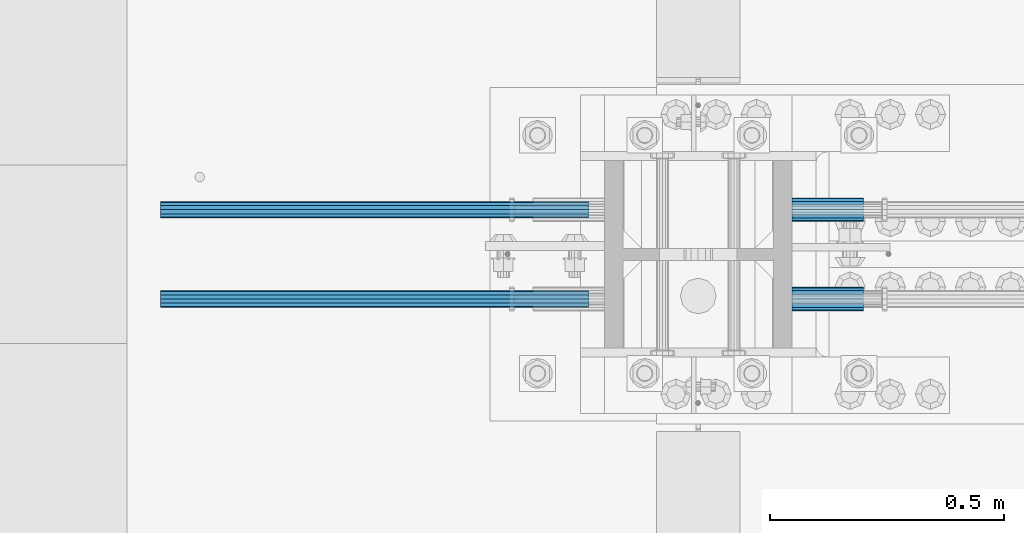
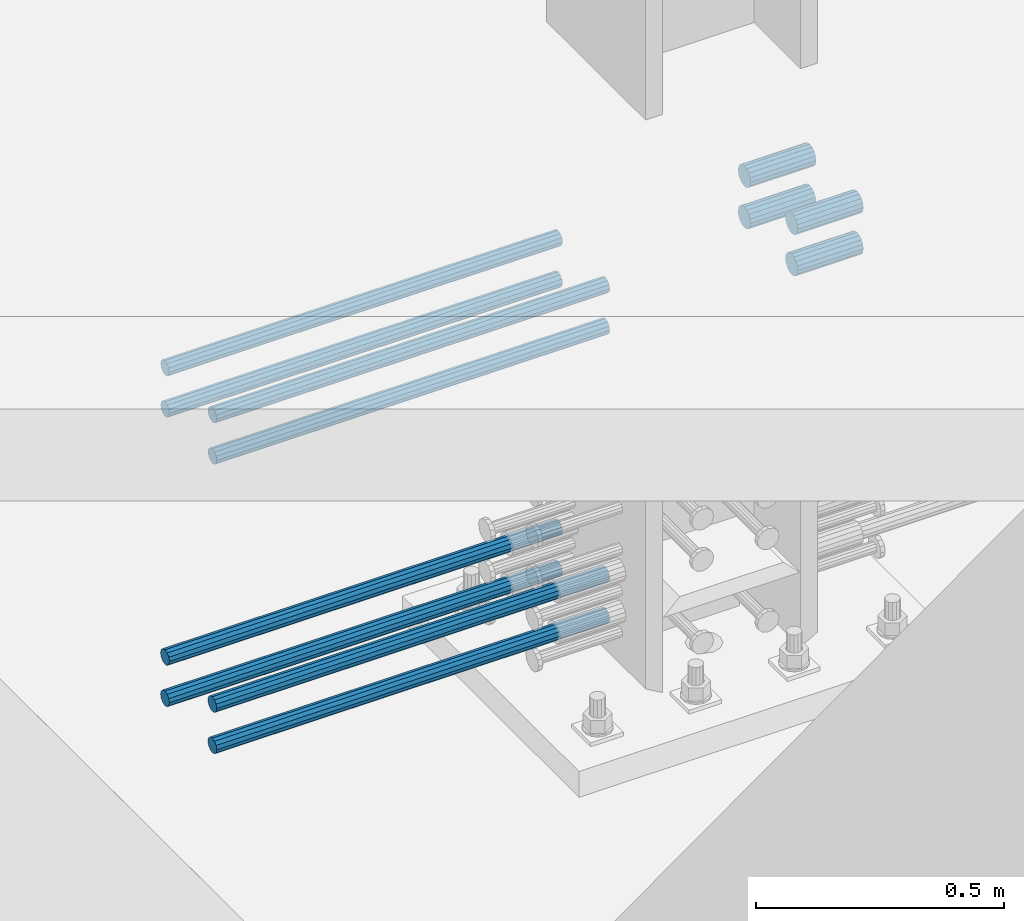
# One storey, part 1188 of 1763: 12 beams, 9 elements without a shape of their own.
"""IFC2X3 building model written with IfcOpenShell, lengths in millimetres."""

import ifcopenshell
import ifcopenshell.guid

model = None  # the IFC model being written
_history = None  # IfcOwnerHistory: only IFC2X3 demands one
_inside = {}  # id of a spatial element -> (the spatial element, [elements in it])
_under = {}  # id of a project, library or spatial element -> (it, [spatial elements below it])
_declared = {}  # id of a project -> (the project, [libraries it declares])
_typed = {}  # id of a type object -> (the type object, [elements of that type])
_made_of = {}  # id of a material, layer set ... -> (it, [elements and type objects made of it])


def new_model(schema):
    """Start an empty IFC model of exactly this schema.

    Asked for "IFC4X3", IfcOpenShell would pick the latest addendum, in which some entities
    have other attributes; the version numbers below select the first issue.
    IFC2X3 requires an IfcOwnerHistory on every rooted entity: one is made here for all.
    """
    global model, _history
    if schema == "IFC4X3":
        model = ifcopenshell.file(schema_version=(4, 3, 0, 0))
    else:
        model = ifcopenshell.file(schema=schema)
    _inside.clear()
    _under.clear()
    _declared.clear()
    _typed.clear()
    _made_of.clear()
    _history = None
    if model.schema == "IFC2X3":
        org = make("IfcOrganization", Name="unknown")
        user = make(
            "IfcPersonAndOrganization",
            ThePerson=make("IfcPerson", FamilyName="unknown"),
            TheOrganization=org,
        )
        app = make(
            "IfcApplication",
            ApplicationDeveloper=org,
            Version="unknown",
            ApplicationFullName="unknown",
            ApplicationIdentifier="unknown",
        )
        _history = make(
            "IfcOwnerHistory",
            OwningUser=user,
            OwningApplication=app,
            ChangeAction="ADDED",
            CreationDate=0,
        )
    return model


def make(cls, **values):
    """One entity of the class cls with the attributes given. An attribute that is None is left unset."""
    return model.create_entity(
        cls, **{name: value for name, value in values.items() if value is not None}
    )


def rooted(cls, **values):
    """An entity with a GlobalId (a new one), such as an element, a storey or a relation."""
    return make(cls, GlobalId=ifcopenshell.guid.new(), OwnerHistory=_history, **values)


def si_unit(unit_type, name, prefix=None):
    """IfcSIUnit, for example si_unit("LENGTHUNIT", "METRE", prefix="MILLI")."""
    return make("IfcSIUnit", UnitType=unit_type, Prefix=prefix, Name=name)


def assignment(units):
    """IfcUnitAssignment: the units of a project."""
    return None if units is None else make("IfcUnitAssignment", Units=units)


def point(xyz):
    """IfcCartesianPoint."""
    return None if xyz is None else make("IfcCartesianPoint", Coordinates=xyz)


def direction(xyz):
    """IfcDirection."""
    return None if xyz is None else make("IfcDirection", DirectionRatios=xyz)


def frame(location, z_axis=None, x_axis=None):
    """IfcAxis2Placement3D, a coordinate frame: its origin and axes. An axis left out is left unset."""
    return make(
        "IfcAxis2Placement3D",
        Location=point(location),
        Axis=direction(z_axis),
        RefDirection=direction(x_axis),
    )


def origin_with_axes():
    """The frame at (0, 0, 0) with the z axis (0, 0, 1) and the x axis (1, 0, 0) written out."""
    return frame((0.0, 0.0, 0.0), z_axis=(0.0, 0.0, 1.0), x_axis=(1.0, 0.0, 0.0))


def place(relative_to, where):
    """IfcLocalPlacement: puts the frame where relative to a parent placement (None: the world)."""
    return make(
        "IfcLocalPlacement", PlacementRelTo=relative_to, RelativePlacement=where
    )


def context(
    kind, dimensions, precision=None, world=None, true_north=None, identifier=None
):
    """IfcGeometricRepresentationContext, for example the 3D "Model" context."""
    return make(
        "IfcGeometricRepresentationContext",
        ContextIdentifier=identifier,
        ContextType=kind,
        CoordinateSpaceDimension=dimensions,
        Precision=precision,
        WorldCoordinateSystem=world,
        TrueNorth=true_north,
    )


def subcontext(parent, identifier, kind, view, scale=None):
    """IfcGeometricRepresentationSubContext, for example "Body" below "Model"."""
    return make(
        "IfcGeometricRepresentationSubContext",
        ContextIdentifier=identifier,
        ContextType=kind,
        ParentContext=parent,
        TargetScale=scale,
        TargetView=view,
    )


def project(units=None, contexts=None):
    """IfcProject with its units and contexts."""
    return rooted(
        "IfcProject",
        Name="project",
        RepresentationContexts=contexts,
        UnitsInContext=assignment(units),
    )


def spatial(cls, under=None, at=None, **own):
    """A site, building, storey or space (cls), placed at a placement, below another one or the project."""
    s = rooted(cls, ObjectPlacement=at, **own)
    if under is not None:
        _under.setdefault(under.id(), (under, []))[1].append(s)
    return s


def faces_of(points, faces, orient=None, outer=None):
    """IfcFace entities. A face is a list of loops; a loop is a list of indices into points, from 0.

    orient and outer hold one flag for each loop. By default every Orientation is true, the
    first loop of a face is its IfcFaceOuterBound and the others are IfcFaceBound.
    """
    made = []
    for i, loops in enumerate(faces):
        bounds = []
        for j, loop in enumerate(loops):
            is_outer = j == 0 if outer is None else outer[i][j]
            bounds.append(
                make(
                    "IfcFaceOuterBound" if is_outer else "IfcFaceBound",
                    Bound=make("IfcPolyLoop", Polygon=[points[k] for k in loop]),
                    Orientation=True if orient is None else orient[i][j],
                )
            )
        made.append(make("IfcFace", Bounds=bounds))
    return made


def faceted_brep(points, faces, orient=None, outer=None, voids=None):
    """IfcFacetedBrep: a solid bounded by flat faces; with voids (closed shells), ...WithVoids."""
    shared = [point(p) for p in points]
    hull = make("IfcClosedShell", CfsFaces=faces_of(shared, faces, orient, outer))
    if voids is None:
        return make("IfcFacetedBrep", Outer=hull)
    return make(
        "IfcFacetedBrepWithVoids",
        Outer=hull,
        Voids=[
            make(cls, CfsFaces=faces_of(shared, fs, o, b)) for cls, fs, o, b in voids
        ],
    )


def shape(context_of_items, identifier, shape_type, items):
    """IfcShapeRepresentation: the items that make up one representation, for example the "Body"."""
    return make(
        "IfcShapeRepresentation",
        ContextOfItems=context_of_items,
        RepresentationIdentifier=identifier,
        RepresentationType=shape_type,
        Items=items,
    )


def material(Name=None, Category=None):
    """IfcMaterial."""
    return make("IfcMaterial", Name=Name, Category=Category)


def made_of(thing, what):
    """Note that an element or type object is made of a material, layer set ...; save() writes the relation."""
    if what is not None:
        _made_of.setdefault(what.id(), (what, []))[1].append(thing)
    return thing


def type_object(cls, material=None, **own):
    """A type object (cls), such as IfcWallType, which elements share."""
    return made_of(rooted(cls, **own), material)


def element(
    cls,
    number,
    at=None,
    inside=None,
    cuts=None,
    type_object=None,
    material=None,
    context=None,
    identifier="Body",
    shape_type=None,
    held_by="IfcProductDefinitionShape",
    body=None,
    shapes=None,
    **own,
):
    """One element of the class cls, such as IfcWall. Its Tag is "e" and its number.

    at: its placement. inside: the storey or other place that contains it. cuts: it is an
    opening in that element (IfcRelVoidsElement). A single representation is given by context,
    identifier, shape_type and body (its items); several are given by shapes. held_by: the class
    of the entity that holds the representations. save() writes the other relations.
    """
    e = rooted(cls, Tag="e%d" % number, ObjectPlacement=at, **own)
    if body is not None:
        shapes = [shape(context, identifier, shape_type, body)]
    if shapes is not None:
        e.Representation = make(held_by, Representations=shapes)
    if inside is not None:
        _inside.setdefault(inside.id(), (inside, []))[1].append(e)
    if cuts is not None:
        rooted(
            "IfcRelVoidsElement", RelatingBuildingElement=cuts, RelatedOpeningElement=e
        )
    if type_object is not None:
        _typed.setdefault(type_object.id(), (type_object, []))[1].append(e)
    return made_of(e, material)


def aggregate(whole, parts):
    """IfcRelAggregates: a whole, such as a stair, and the parts it consists of."""
    return rooted("IfcRelAggregates", RelatingObject=whole, RelatedObjects=parts)


def save(model, path):
    """Write the relations noted so far, then the file.

    IfcRelAggregates (storeys below a building ...), IfcRelContainedInSpatialStructure (elements
    in a storey), IfcRelDefinesByType, IfcRelAssociatesMaterial and IfcRelDeclares: one each for
    every whole, place, type object, material and project.
    """
    for whole, parts in _under.values():
        aggregate(whole, parts)
    for where, things in _inside.values():
        rooted(
            "IfcRelContainedInSpatialStructure",
            RelatedElements=things,
            RelatingStructure=where,
        )
    for kind, things in _typed.values():
        rooted("IfcRelDefinesByType", RelatedObjects=things, RelatingType=kind)
    for what, things in _made_of.values():
        rooted("IfcRelAssociatesMaterial", RelatedObjects=things, RelatingMaterial=what)
    for by, libraries in _declared.values():
        rooted("IfcRelDeclares", RelatingContext=by, RelatedDefinitions=libraries)
    model.write(path)


model = new_model("IFC2X3")

# Units and contexts
model_context = context("Model", 3, precision=1e-05, world=origin_with_axes())
body_context = subcontext(model_context, "Body", "Model", "MODEL_VIEW")
ifc_project = project(units=[si_unit("LENGTHUNIT", "METRE", prefix="MILLI"), si_unit("AREAUNIT", "SQUARE_METRE"), si_unit("VOLUMEUNIT", "CUBIC_METRE"), si_unit("MASSUNIT", "GRAM", prefix="KILO"), si_unit("TIMEUNIT", "SECOND"), si_unit("PLANEANGLEUNIT", "RADIAN"), si_unit("SOLIDANGLEUNIT", "STERADIAN"), si_unit("THERMODYNAMICTEMPERATUREUNIT", "DEGREE_CELSIUS"), si_unit("LUMINOUSINTENSITYUNIT", "LUMEN")], contexts=[model_context])

# Site, building, storey
site_placement = place(None, origin_with_axes())
site = spatial("IfcSite", under=ifc_project, at=site_placement, CompositionType="ELEMENT")
building_placement = place(site_placement, origin_with_axes())
building = spatial("IfcBuilding", under=site, at=building_placement, Name="Undefined", CompositionType="ELEMENT")
storey_placement = place(building_placement, origin_with_axes())
storey = spatial("IfcBuildingStorey", under=building, at=storey_placement, Name="Undefined", CompositionType="ELEMENT", Elevation=0.0)

# Assembly, beams
assembly_1_placement = place(storey_placement, origin_with_axes())
assembly_1 = element("IfcElementAssembly", 1, at=assembly_1_placement, inside=storey, Name="COLUMN", AssemblyPlace="NOTDEFINED", PredefinedType="RIGID_FRAME")
ifc_material = material(Name="STEEL/A706-GR.80")
beam_type_1 = type_object("IfcBeamType", PredefinedType="NOTDEFINED")
beam_1_placement = place(assembly_1_placement, frame((-72291.0122736972, 552.450000000255, 4775.20000000008), z_axis=(0.0, 0.0, 1.0), x_axis=(1.0, 0.0, 0.0)))
beam_1 = element("IfcBeam", 2, at=beam_1_placement, type_object=beam_type_1, material=ifc_material, Name="HALF COUPLER F", context=body_context, shape_type="Brep", body=[
    faceted_brep([(32.7659999999996, -8.95349999999962, -15.507916905568), (32.7659999999996, 0.0, -17.9070000000002), (32.7659999999996, 8.95349999999962, -15.507916905568), (32.7659999999996, 15.507916905568, -8.95350000000008), (32.7659999999996, 17.9069999999992, 0.0), (32.7659999999996, 15.507916905568, 8.95350000000008), (32.7659999999996, 8.95349999999962, 15.507916905568), (32.7659999999996, 0.0, 17.9070000000002), (32.7659999999996, -8.95349999999962, 15.507916905568), (32.7659999999996, -15.507916905568, 8.95350000000008), (32.7659999999996, -17.9069999999992, 0.0), (32.7659999999996, -15.507916905568, -8.95350000000008), (152.400103102711, -15.507916905568, 8.95350000000008), (152.400103102711, -8.95349999999962, 15.507916905568), (152.400103102711, -17.9069999999992, 0.0), (152.400103102711, -15.507916905568, -8.95350000000008), (152.400103102711, -8.95349999999962, -15.507916905568), (152.400103102711, 0.0, -17.9070000000002), (152.400103102711, 8.95349999999962, -15.507916905568), (152.400103102711, 15.507916905568, -8.95350000000008), (152.400103102711, 17.9069999999992, 0.0), (152.400103102711, 15.507916905568, 8.95350000000008), (152.400103102711, 8.95349999999962, 15.507916905568), (152.400103102711, 0.0, 17.9070000000002), (0.0, -23.466540125788, 9.72015918207308), (0.0, -17.9605122421381, 17.9605122421385), (0.0, -9.72015918207398, 23.4665401257867), (0.0, 0.0, 25.4000000000001), (0.0, 9.72015918207398, 23.4665401257867), (0.0, 17.9605122421381, 17.9605122421385), (0.0, 23.466540125788, 9.72015918207308), (0.0, 25.4000000000015, 0.0), (0.0, 23.466540125788, -9.72015918207308), (0.0, 17.9605122421381, -17.9605122421385), (0.0, 9.72015918207398, -23.4665401257867), (0.0, 0.0, -25.4000000000001), (0.0, -9.72015918207398, -23.4665401257867), (0.0, -17.9605122421381, -17.9605122421385), (0.0, -23.466540125788, -9.72015918207308), (0.0, -25.4000000000015, 0.0), (152.400103102711, -25.4000000000015, 0.0), (152.400103102711, -23.466540125788, 9.72015918207308), (152.400103102711, -17.9605122421381, 17.9605122421385), (152.400103102711, -9.72015918207398, 23.4665401257867), (152.400103102711, 0.0, 25.4000000000001), (152.400103102711, 9.72015918207398, 23.4665401257867), (152.400103102711, 17.9605122421381, 17.9605122421385), (152.400103102711, 23.466540125788, 9.72015918207308), (152.400103102711, 25.4000000000015, 0.0), (152.400103102711, 23.466540125788, -9.72015918207308), (152.400103102711, 17.9605122421381, -17.9605122421385), (152.400103102711, 9.72015918207398, -23.4665401257867), (152.400103102711, 0.0, -25.4000000000001), (152.400103102711, -9.72015918207398, -23.4665401257867), (152.400103102711, -17.9605122421381, -17.9605122421385), (152.400103102711, -23.466540125788, -9.72015918207308)], [[[0, 1, 2, 3, 4, 5, 6, 7, 8, 9, 10, 11]], [[12, 9, 8, 13]], [[14, 10, 9, 12]], [[15, 11, 10, 14]], [[16, 0, 11, 15]], [[17, 1, 0, 16]], [[18, 2, 1, 17]], [[19, 3, 2, 18]], [[20, 4, 3, 19]], [[21, 5, 4, 20]], [[22, 6, 5, 21]], [[23, 7, 6, 22]], [[13, 8, 7, 23]], [[24, 25, 26, 27, 28, 29, 30, 31, 32, 33, 34, 35, 36, 37, 38, 39]], [[24, 39, 40, 41]], [[25, 24, 41, 42]], [[26, 25, 42, 43]], [[27, 26, 43, 44]], [[28, 27, 44, 45]], [[29, 28, 45, 46]], [[30, 29, 46, 47]], [[31, 30, 47, 48]], [[32, 31, 48, 49]], [[33, 32, 49, 50]], [[34, 33, 50, 51]], [[35, 34, 51, 52]], [[36, 35, 52, 53]], [[37, 36, 53, 54]], [[38, 37, 54, 55]], [[39, 38, 55, 40]], [[54, 53, 52, 51, 50, 49, 48, 47, 46, 45, 44, 43, 42, 41, 40, 55], [21, 20, 19, 18, 17, 16, 15, 14, 12, 13, 23, 22]]]),
])
beam_2_placement = place(assembly_1_placement, frame((-72291.012342359, 361.950000000843, 4775.20000000008), z_axis=(0.0, 0.0, 1.0), x_axis=(1.0, 0.0, 0.0)))
beam_2 = element("IfcBeam", 3, at=beam_2_placement, type_object=beam_type_1, material=ifc_material, Name="HALF COUPLER F", context=body_context, shape_type="Brep", body=[
    faceted_brep([(32.7659999999996, -8.95349999999962, -15.507916905568), (32.7659999999996, 0.0, -17.9070000000002), (32.7659999999996, 8.95349999999962, -15.507916905568), (32.7659999999996, 15.507916905568, -8.95350000000008), (32.7659999999996, 17.9069999999992, 0.0), (32.7659999999996, 15.507916905568, 8.95350000000008), (32.7659999999996, 8.95349999999962, 15.507916905568), (32.7659999999996, 0.0, 17.9070000000002), (32.7659999999996, -8.95349999999962, 15.507916905568), (32.7659999999996, -15.507916905568, 8.95350000000008), (32.7659999999996, -17.9069999999992, 0.0), (32.7659999999996, -15.507916905568, -8.95350000000008), (152.400103102711, -15.507916905568, 8.95350000000008), (152.400103102711, -8.95349999999962, 15.507916905568), (152.400103102711, -17.9069999999992, 0.0), (152.400103102711, -15.507916905568, -8.95350000000008), (152.400103102711, -8.95349999999962, -15.507916905568), (152.400103102711, 0.0, -17.9070000000002), (152.400103102711, 8.95349999999962, -15.507916905568), (152.400103102711, 15.507916905568, -8.95350000000008), (152.400103102711, 17.9069999999992, 0.0), (152.400103102711, 15.507916905568, 8.95350000000008), (152.400103102711, 8.95349999999962, 15.507916905568), (152.400103102711, 0.0, 17.9070000000002), (0.0, -23.466540125788, 9.72015918207308), (0.0, -17.9605122421381, 17.9605122421385), (0.0, -9.72015918207398, 23.4665401257867), (0.0, 0.0, 25.4000000000001), (0.0, 9.72015918207398, 23.4665401257867), (0.0, 17.9605122421381, 17.9605122421385), (0.0, 23.466540125788, 9.72015918207308), (0.0, 25.4000000000015, 0.0), (0.0, 23.466540125788, -9.72015918207308), (0.0, 17.9605122421381, -17.9605122421385), (0.0, 9.72015918207398, -23.4665401257867), (0.0, 0.0, -25.4000000000001), (0.0, -9.72015918207398, -23.4665401257867), (0.0, -17.9605122421381, -17.9605122421385), (0.0, -23.466540125788, -9.72015918207308), (0.0, -25.4000000000015, 0.0), (152.400103102711, -25.4000000000015, 0.0), (152.400103102711, -23.466540125788, 9.72015918207308), (152.400103102711, -17.9605122421381, 17.9605122421385), (152.400103102711, -9.72015918207398, 23.4665401257867), (152.400103102711, 0.0, 25.4000000000001), (152.400103102711, 9.72015918207398, 23.4665401257867), (152.400103102711, 17.9605122421381, 17.9605122421385), (152.400103102711, 23.466540125788, 9.72015918207308), (152.400103102711, 25.4000000000015, 0.0), (152.400103102711, 23.466540125788, -9.72015918207308), (152.400103102711, 17.9605122421381, -17.9605122421385), (152.400103102711, 9.72015918207398, -23.4665401257867), (152.400103102711, 0.0, -25.4000000000001), (152.400103102711, -9.72015918207398, -23.4665401257867), (152.400103102711, -17.9605122421381, -17.9605122421385), (152.400103102711, -23.466540125788, -9.72015918207308)], [[[0, 1, 2, 3, 4, 5, 6, 7, 8, 9, 10, 11]], [[12, 9, 8, 13]], [[14, 10, 9, 12]], [[15, 11, 10, 14]], [[16, 0, 11, 15]], [[17, 1, 0, 16]], [[18, 2, 1, 17]], [[19, 3, 2, 18]], [[20, 4, 3, 19]], [[21, 5, 4, 20]], [[22, 6, 5, 21]], [[23, 7, 6, 22]], [[13, 8, 7, 23]], [[24, 25, 26, 27, 28, 29, 30, 31, 32, 33, 34, 35, 36, 37, 38, 39]], [[24, 39, 40, 41]], [[25, 24, 41, 42]], [[26, 25, 42, 43]], [[27, 26, 43, 44]], [[28, 27, 44, 45]], [[29, 28, 45, 46]], [[30, 29, 46, 47]], [[31, 30, 47, 48]], [[32, 31, 48, 49]], [[33, 32, 49, 50]], [[34, 33, 50, 51]], [[35, 34, 51, 52]], [[36, 35, 52, 53]], [[37, 36, 53, 54]], [[38, 37, 54, 55]], [[39, 38, 55, 40]], [[54, 53, 52, 51, 50, 49, 48, 47, 46, 45, 44, 43, 42, 41, 40, 55], [21, 20, 19, 18, 17, 16, 15, 14, 12, 13, 23, 22]]]),
])
beam_3_placement = place(assembly_1_placement, frame((-72291.0122736972, 552.450000000255, 4876.80000000008), z_axis=(0.0, 0.0, 1.0), x_axis=(1.0, 0.0, 0.0)))
beam_3 = element("IfcBeam", 4, at=beam_3_placement, type_object=beam_type_1, material=ifc_material, Name="HALF COUPLER F", context=body_context, shape_type="Brep", body=[
    faceted_brep([(32.7659999999996, -8.95349999999962, -15.507916905568), (32.7659999999996, 0.0, -17.9070000000002), (32.7659999999996, 8.95349999999962, -15.507916905568), (32.7659999999996, 15.507916905568, -8.95350000000008), (32.7659999999996, 17.9069999999992, 0.0), (32.7659999999996, 15.507916905568, 8.95350000000008), (32.7659999999996, 8.95349999999962, 15.507916905568), (32.7659999999996, 0.0, 17.9070000000002), (32.7659999999996, -8.95349999999962, 15.507916905568), (32.7659999999996, -15.507916905568, 8.95350000000008), (32.7659999999996, -17.9069999999992, 0.0), (32.7659999999996, -15.507916905568, -8.95350000000008), (152.400103102711, -15.507916905568, 8.95350000000008), (152.400103102711, -8.95349999999962, 15.507916905568), (152.400103102711, -17.9069999999992, 0.0), (152.400103102711, -15.507916905568, -8.95350000000008), (152.400103102711, -8.95349999999962, -15.507916905568), (152.400103102711, 0.0, -17.9070000000002), (152.400103102711, 8.95349999999962, -15.507916905568), (152.400103102711, 15.507916905568, -8.95350000000008), (152.400103102711, 17.9069999999992, 0.0), (152.400103102711, 15.507916905568, 8.95350000000008), (152.400103102711, 8.95349999999962, 15.507916905568), (152.400103102711, 0.0, 17.9070000000002), (0.0, -23.466540125788, 9.72015918207308), (0.0, -17.9605122421381, 17.9605122421385), (0.0, -9.72015918207398, 23.4665401257867), (0.0, 0.0, 25.4000000000001), (0.0, 9.72015918207398, 23.4665401257867), (0.0, 17.9605122421381, 17.9605122421385), (0.0, 23.466540125788, 9.72015918207308), (0.0, 25.4000000000015, 0.0), (0.0, 23.466540125788, -9.72015918207308), (0.0, 17.9605122421381, -17.9605122421385), (0.0, 9.72015918207398, -23.4665401257867), (0.0, 0.0, -25.4000000000001), (0.0, -9.72015918207398, -23.4665401257867), (0.0, -17.9605122421381, -17.9605122421385), (0.0, -23.466540125788, -9.72015918207308), (0.0, -25.4000000000015, 0.0), (152.400103102711, -25.4000000000015, 0.0), (152.400103102711, -23.466540125788, 9.72015918207308), (152.400103102711, -17.9605122421381, 17.9605122421385), (152.400103102711, -9.72015918207398, 23.4665401257867), (152.400103102711, 0.0, 25.4000000000001), (152.400103102711, 9.72015918207398, 23.4665401257867), (152.400103102711, 17.9605122421381, 17.9605122421385), (152.400103102711, 23.466540125788, 9.72015918207308), (152.400103102711, 25.4000000000015, 0.0), (152.400103102711, 23.466540125788, -9.72015918207308), (152.400103102711, 17.9605122421381, -17.9605122421385), (152.400103102711, 9.72015918207398, -23.4665401257867), (152.400103102711, 0.0, -25.4000000000001), (152.400103102711, -9.72015918207398, -23.4665401257867), (152.400103102711, -17.9605122421381, -17.9605122421385), (152.400103102711, -23.466540125788, -9.72015918207308)], [[[0, 1, 2, 3, 4, 5, 6, 7, 8, 9, 10, 11]], [[12, 9, 8, 13]], [[14, 10, 9, 12]], [[15, 11, 10, 14]], [[16, 0, 11, 15]], [[17, 1, 0, 16]], [[18, 2, 1, 17]], [[19, 3, 2, 18]], [[20, 4, 3, 19]], [[21, 5, 4, 20]], [[22, 6, 5, 21]], [[23, 7, 6, 22]], [[13, 8, 7, 23]], [[24, 25, 26, 27, 28, 29, 30, 31, 32, 33, 34, 35, 36, 37, 38, 39]], [[24, 39, 40, 41]], [[25, 24, 41, 42]], [[26, 25, 42, 43]], [[27, 26, 43, 44]], [[28, 27, 44, 45]], [[29, 28, 45, 46]], [[30, 29, 46, 47]], [[31, 30, 47, 48]], [[32, 31, 48, 49]], [[33, 32, 49, 50]], [[34, 33, 50, 51]], [[35, 34, 51, 52]], [[36, 35, 52, 53]], [[37, 36, 53, 54]], [[38, 37, 54, 55]], [[39, 38, 55, 40]], [[54, 53, 52, 51, 50, 49, 48, 47, 46, 45, 44, 43, 42, 41, 40, 55], [21, 20, 19, 18, 17, 16, 15, 14, 12, 13, 23, 22]]]),
])
beam_4_placement = place(assembly_1_placement, frame((-72291.012342359, 361.950000000843, 4876.80000000008), z_axis=(0.0, 0.0, 1.0), x_axis=(1.0, 0.0, 0.0)))
beam_4 = element("IfcBeam", 5, at=beam_4_placement, type_object=beam_type_1, material=ifc_material, Name="HALF COUPLER F", context=body_context, shape_type="Brep", body=[
    faceted_brep([(32.7659999999996, -8.95349999999962, -15.507916905568), (32.7659999999996, 0.0, -17.9070000000002), (32.7659999999996, 8.95349999999962, -15.507916905568), (32.7659999999996, 15.507916905568, -8.95350000000008), (32.7659999999996, 17.9069999999992, 0.0), (32.7659999999996, 15.507916905568, 8.95350000000008), (32.7659999999996, 8.95349999999962, 15.507916905568), (32.7659999999996, 0.0, 17.9070000000002), (32.7659999999996, -8.95349999999962, 15.507916905568), (32.7659999999996, -15.507916905568, 8.95350000000008), (32.7659999999996, -17.9069999999992, 0.0), (32.7659999999996, -15.507916905568, -8.95350000000008), (152.400103102711, -15.507916905568, 8.95350000000008), (152.400103102711, -8.95349999999962, 15.507916905568), (152.400103102711, -17.9069999999992, 0.0), (152.400103102711, -15.507916905568, -8.95350000000008), (152.400103102711, -8.95349999999962, -15.507916905568), (152.400103102711, 0.0, -17.9070000000002), (152.400103102711, 8.95349999999962, -15.507916905568), (152.400103102711, 15.507916905568, -8.95350000000008), (152.400103102711, 17.9069999999992, 0.0), (152.400103102711, 15.507916905568, 8.95350000000008), (152.400103102711, 8.95349999999962, 15.507916905568), (152.400103102711, 0.0, 17.9070000000002), (0.0, -23.466540125788, 9.72015918207308), (0.0, -17.9605122421381, 17.9605122421385), (0.0, -9.72015918207398, 23.4665401257867), (0.0, 0.0, 25.4000000000001), (0.0, 9.72015918207398, 23.4665401257867), (0.0, 17.9605122421381, 17.9605122421385), (0.0, 23.466540125788, 9.72015918207308), (0.0, 25.4000000000015, 0.0), (0.0, 23.466540125788, -9.72015918207308), (0.0, 17.9605122421381, -17.9605122421385), (0.0, 9.72015918207398, -23.4665401257867), (0.0, 0.0, -25.4000000000001), (0.0, -9.72015918207398, -23.4665401257867), (0.0, -17.9605122421381, -17.9605122421385), (0.0, -23.466540125788, -9.72015918207308), (0.0, -25.4000000000015, 0.0), (152.400103102711, -25.4000000000015, 0.0), (152.400103102711, -23.466540125788, 9.72015918207308), (152.400103102711, -17.9605122421381, 17.9605122421385), (152.400103102711, -9.72015918207398, 23.4665401257867), (152.400103102711, 0.0, 25.4000000000001), (152.400103102711, 9.72015918207398, 23.4665401257867), (152.400103102711, 17.9605122421381, 17.9605122421385), (152.400103102711, 23.466540125788, 9.72015918207308), (152.400103102711, 25.4000000000015, 0.0), (152.400103102711, 23.466540125788, -9.72015918207308), (152.400103102711, 17.9605122421381, -17.9605122421385), (152.400103102711, 9.72015918207398, -23.4665401257867), (152.400103102711, 0.0, -25.4000000000001), (152.400103102711, -9.72015918207398, -23.4665401257867), (152.400103102711, -17.9605122421381, -17.9605122421385), (152.400103102711, -23.466540125788, -9.72015918207308)], [[[0, 1, 2, 3, 4, 5, 6, 7, 8, 9, 10, 11]], [[12, 9, 8, 13]], [[14, 10, 9, 12]], [[15, 11, 10, 14]], [[16, 0, 11, 15]], [[17, 1, 0, 16]], [[18, 2, 1, 17]], [[19, 3, 2, 18]], [[20, 4, 3, 19]], [[21, 5, 4, 20]], [[22, 6, 5, 21]], [[23, 7, 6, 22]], [[13, 8, 7, 23]], [[24, 25, 26, 27, 28, 29, 30, 31, 32, 33, 34, 35, 36, 37, 38, 39]], [[24, 39, 40, 41]], [[25, 24, 41, 42]], [[26, 25, 42, 43]], [[27, 26, 43, 44]], [[28, 27, 44, 45]], [[29, 28, 45, 46]], [[30, 29, 46, 47]], [[31, 30, 47, 48]], [[32, 31, 48, 49]], [[33, 32, 49, 50]], [[34, 33, 50, 51]], [[35, 34, 51, 52]], [[36, 35, 52, 53]], [[37, 36, 53, 54]], [[38, 37, 54, 55]], [[39, 38, 55, 40]], [[54, 53, 52, 51, 50, 49, 48, 47, 46, 45, 44, 43, 42, 41, 40, 55], [21, 20, 19, 18, 17, 16, 15, 14, 12, 13, 23, 22]]]),
])
aggregate(assembly_1, [beam_1, beam_2, beam_3, beam_4])

# Assembly, beam
assembly_2_placement = place(storey_placement, origin_with_axes())
assembly_2 = element("IfcElementAssembly", 6, at=assembly_2_placement, inside=storey, Name="REBAR", AssemblyPlace="NOTDEFINED", PredefinedType="RIGID_FRAME")
beam_type_2 = type_object("IfcBeamType", Name="#11 REBAR", PredefinedType="NOTDEFINED")
beam_5_placement = place(assembly_2_placement, frame((-72723.8282048462, 361.949999998293, 4063.99999999999), z_axis=(0.0, 0.0, -1.0), x_axis=(-1.0, 0.0, 0.0)))
beam_5 = element("IfcBeam", 7, at=beam_5_placement, type_object=beam_type_2, material=ifc_material, Name="REBAR", ObjectType="#11 REBAR", context=body_context, shape_type="Brep", body=[
    faceted_brep([(0.0, -17.9069999999992, 0.0), (0.0, -15.507916905568, -8.95349999999962), (914.400000001086, -15.507916905568, -8.95349999999962), (914.400000001086, -17.9069999999992, 0.0), (0.0, -8.95349999999962, -15.507916905568), (914.400000001086, -8.95349999999962, -15.507916905568), (0.0, 0.0, -17.9070000000002), (914.400000001086, 0.0, -17.9070000000002), (0.0, 8.95349999999962, -15.507916905568), (914.400000001086, 8.95349999999962, -15.507916905568), (0.0, 15.507916905568, -8.95349999999962), (914.400000001086, 15.507916905568, -8.95349999999962), (0.0, 17.9069999999992, 0.0), (914.400000001086, 17.9069999999992, 0.0), (0.0, 15.507916905568, 8.95349999999962), (914.400000001086, 15.507916905568, 8.95349999999962), (0.0, 8.95349999999962, 15.507916905568), (914.400000001086, 8.95349999999962, 15.507916905568), (0.0, 0.0, 17.9070000000002), (914.400000001086, 0.0, 17.9070000000002), (0.0, -8.95349999999962, 15.507916905568), (914.400000001086, -8.95349999999962, 15.507916905568), (0.0, -15.507916905568, 8.95349999999962), (914.400000001086, -15.507916905568, 8.95349999999962)], [[[0, 1, 2, 3]], [[1, 4, 5, 2]], [[4, 6, 7, 5]], [[6, 8, 9, 7]], [[8, 10, 11, 9]], [[10, 12, 13, 11]], [[12, 14, 15, 13]], [[14, 16, 17, 15]], [[16, 18, 19, 17]], [[18, 20, 21, 19]], [[20, 22, 23, 21]], [[22, 0, 3, 23]], [[5, 7, 9, 11, 13, 15, 17, 19, 21, 23, 3, 2]], [[22, 20, 18, 16, 14, 12, 10, 8, 6, 4, 1, 0]]]),
])
aggregate(assembly_2, [beam_5])

assembly_3_placement = place(storey_placement, origin_with_axes())
assembly_3 = element("IfcElementAssembly", 8, at=assembly_3_placement, inside=storey, Name="REBAR", AssemblyPlace="NOTDEFINED", PredefinedType="RIGID_FRAME")
beam_6_placement = place(assembly_3_placement, frame((-72723.8282736972, 552.449999997709, 4063.99999999999), z_axis=(0.0, 0.0, -1.0), x_axis=(-1.0, 0.0, 0.0)))
beam_6 = element("IfcBeam", 9, at=beam_6_placement, type_object=beam_type_2, material=ifc_material, Name="REBAR", ObjectType="#11 REBAR", context=body_context, shape_type="Brep", body=[
    faceted_brep([(0.0, -17.9069999999992, 0.0), (0.0, -15.507916905568, -8.95349999999962), (914.400000001086, -15.507916905568, -8.95349999999962), (914.400000001086, -17.9069999999992, 0.0), (0.0, -8.95349999999962, -15.507916905568), (914.400000001086, -8.95349999999962, -15.507916905568), (0.0, 0.0, -17.9070000000002), (914.400000001086, 0.0, -17.9070000000002), (0.0, 8.95349999999962, -15.507916905568), (914.400000001086, 8.95349999999962, -15.507916905568), (0.0, 15.507916905568, -8.95349999999962), (914.400000001086, 15.507916905568, -8.95349999999962), (0.0, 17.9069999999992, 0.0), (914.400000001086, 17.9069999999992, 0.0), (0.0, 15.507916905568, 8.95349999999962), (914.400000001086, 15.507916905568, 8.95349999999962), (0.0, 8.95349999999962, 15.507916905568), (914.400000001086, 8.95349999999962, 15.507916905568), (0.0, 0.0, 17.9070000000002), (914.400000001086, 0.0, 17.9070000000002), (0.0, -8.95349999999962, 15.507916905568), (914.400000001086, -8.95349999999962, 15.507916905568), (0.0, -15.507916905568, 8.95349999999962), (914.400000001086, -15.507916905568, 8.95349999999962)], [[[0, 1, 2, 3]], [[1, 4, 5, 2]], [[4, 6, 7, 5]], [[6, 8, 9, 7]], [[8, 10, 11, 9]], [[10, 12, 13, 11]], [[12, 14, 15, 13]], [[14, 16, 17, 15]], [[16, 18, 19, 17]], [[18, 20, 21, 19]], [[20, 22, 23, 21]], [[22, 0, 3, 23]], [[5, 7, 9, 11, 13, 15, 17, 19, 21, 23, 3, 2]], [[22, 20, 18, 16, 14, 12, 10, 8, 6, 4, 1, 0]]]),
])
aggregate(assembly_3, [beam_6])

assembly_4_placement = place(storey_placement, origin_with_axes())
assembly_4 = element("IfcElementAssembly", 10, at=assembly_4_placement, inside=storey, Name="REBAR", AssemblyPlace="NOTDEFINED", PredefinedType="RIGID_FRAME")
beam_7_placement = place(assembly_4_placement, frame((-72723.8282048462, 361.949999998296, 4165.59999999999), z_axis=(0.0, 0.0, -1.0), x_axis=(-1.0, 0.0, 0.0)))
beam_7 = element("IfcBeam", 11, at=beam_7_placement, type_object=beam_type_2, material=ifc_material, Name="REBAR", ObjectType="#11 REBAR", context=body_context, shape_type="Brep", body=[
    faceted_brep([(0.0, -17.9069999999992, 0.0), (0.0, -15.507916905568, -8.95349999999962), (914.400000001086, -15.507916905568, -8.95349999999962), (914.400000001086, -17.9069999999992, 0.0), (0.0, -8.95349999999962, -15.507916905568), (914.400000001086, -8.95349999999962, -15.507916905568), (0.0, 0.0, -17.9070000000002), (914.400000001086, 0.0, -17.9070000000002), (0.0, 8.95349999999962, -15.507916905568), (914.400000001086, 8.95349999999962, -15.507916905568), (0.0, 15.507916905568, -8.95349999999962), (914.400000001086, 15.507916905568, -8.95349999999962), (0.0, 17.9069999999992, 0.0), (914.400000001086, 17.9069999999992, 0.0), (0.0, 15.507916905568, 8.95349999999962), (914.400000001086, 15.507916905568, 8.95349999999962), (0.0, 8.95349999999962, 15.507916905568), (914.400000001086, 8.95349999999962, 15.507916905568), (0.0, 0.0, 17.9070000000002), (914.400000001086, 0.0, 17.9070000000002), (0.0, -8.95349999999962, 15.507916905568), (914.400000001086, -8.95349999999962, 15.507916905568), (0.0, -15.507916905568, 8.95349999999962), (914.400000001086, -15.507916905568, 8.95349999999962)], [[[0, 1, 2, 3]], [[1, 4, 5, 2]], [[4, 6, 7, 5]], [[6, 8, 9, 7]], [[8, 10, 11, 9]], [[10, 12, 13, 11]], [[12, 14, 15, 13]], [[14, 16, 17, 15]], [[16, 18, 19, 17]], [[18, 20, 21, 19]], [[20, 22, 23, 21]], [[22, 0, 3, 23]], [[5, 7, 9, 11, 13, 15, 17, 19, 21, 23, 3, 2]], [[22, 20, 18, 16, 14, 12, 10, 8, 6, 4, 1, 0]]]),
])
aggregate(assembly_4, [beam_7])

assembly_5_placement = place(storey_placement, origin_with_axes())
assembly_5 = element("IfcElementAssembly", 12, at=assembly_5_placement, inside=storey, Name="REBAR", AssemblyPlace="NOTDEFINED", PredefinedType="RIGID_FRAME")
beam_8_placement = place(assembly_5_placement, frame((-72723.8282736972, 552.449999997712, 4165.59999999999), z_axis=(0.0, 0.0, -1.0), x_axis=(-1.0, 0.0, 0.0)))
beam_8 = element("IfcBeam", 13, at=beam_8_placement, type_object=beam_type_2, material=ifc_material, Name="REBAR", ObjectType="#11 REBAR", context=body_context, shape_type="Brep", body=[
    faceted_brep([(0.0, -17.9069999999992, 0.0), (0.0, -15.507916905568, -8.95349999999962), (914.400000001086, -15.507916905568, -8.95349999999962), (914.400000001086, -17.9069999999992, 0.0), (0.0, -8.95349999999962, -15.507916905568), (914.400000001086, -8.95349999999962, -15.507916905568), (0.0, 0.0, -17.9070000000002), (914.400000001086, 0.0, -17.9070000000002), (0.0, 8.95349999999962, -15.507916905568), (914.400000001086, 8.95349999999962, -15.507916905568), (0.0, 15.507916905568, -8.95349999999962), (914.400000001086, 15.507916905568, -8.95349999999962), (0.0, 17.9069999999992, 0.0), (914.400000001086, 17.9069999999992, 0.0), (0.0, 15.507916905568, 8.95349999999962), (914.400000001086, 15.507916905568, 8.95349999999962), (0.0, 8.95349999999962, 15.507916905568), (914.400000001086, 8.95349999999962, 15.507916905568), (0.0, 0.0, 17.9070000000002), (914.400000001086, 0.0, 17.9070000000002), (0.0, -8.95349999999962, 15.507916905568), (914.400000001086, -8.95349999999962, 15.507916905568), (0.0, -15.507916905568, 8.95349999999962), (914.400000001086, -15.507916905568, 8.95349999999962)], [[[0, 1, 2, 3]], [[1, 4, 5, 2]], [[4, 6, 7, 5]], [[6, 8, 9, 7]], [[8, 10, 11, 9]], [[10, 12, 13, 11]], [[12, 14, 15, 13]], [[14, 16, 17, 15]], [[16, 18, 19, 17]], [[18, 20, 21, 19]], [[20, 22, 23, 21]], [[22, 0, 3, 23]], [[5, 7, 9, 11, 13, 15, 17, 19, 21, 23, 3, 2]], [[22, 20, 18, 16, 14, 12, 10, 8, 6, 4, 1, 0]]]),
])
aggregate(assembly_5, [beam_8])

assembly_6_placement = place(storey_placement, origin_with_axes())
assembly_6 = element("IfcElementAssembly", 14, at=assembly_6_placement, inside=storey, Name="REBAR", AssemblyPlace="NOTDEFINED", PredefinedType="RIGID_FRAME")
beam_9_placement = place(assembly_6_placement, frame((-72723.8282735816, 361.949999999568, 4775.20000000006), z_axis=(0.0, 0.0, -1.0), x_axis=(-1.0, 0.0, 0.0)))
beam_9 = element("IfcBeam", 15, at=beam_9_placement, type_object=beam_type_2, material=ifc_material, Name="REBAR", ObjectType="#11 REBAR", context=body_context, shape_type="Brep", body=[
    faceted_brep([(0.0, -17.9069999999992, 0.0), (0.0, -15.507916905568, -8.95349999999962), (914.400000001086, -15.507916905568, -8.95349999999962), (914.400000001086, -17.9069999999992, 0.0), (0.0, -8.95349999999962, -15.507916905568), (914.400000001086, -8.95349999999962, -15.507916905568), (0.0, 0.0, -17.9070000000002), (914.400000001086, 0.0, -17.9070000000002), (0.0, 8.95349999999962, -15.507916905568), (914.400000001086, 8.95349999999962, -15.507916905568), (0.0, 15.507916905568, -8.95349999999962), (914.400000001086, 15.507916905568, -8.95349999999962), (0.0, 17.9069999999992, 0.0), (914.400000001086, 17.9069999999992, 0.0), (0.0, 15.507916905568, 8.95349999999962), (914.400000001086, 15.507916905568, 8.95349999999962), (0.0, 8.95349999999962, 15.507916905568), (914.400000001086, 8.95349999999962, 15.507916905568), (0.0, 0.0, 17.9070000000002), (914.400000001086, 0.0, 17.9070000000002), (0.0, -8.95349999999962, 15.507916905568), (914.400000001086, -8.95349999999962, 15.507916905568), (0.0, -15.507916905568, 8.95349999999962), (914.400000001086, -15.507916905568, 8.95349999999962)], [[[0, 1, 2, 3]], [[1, 4, 5, 2]], [[4, 6, 7, 5]], [[6, 8, 9, 7]], [[8, 10, 11, 9]], [[10, 12, 13, 11]], [[12, 14, 15, 13]], [[14, 16, 17, 15]], [[16, 18, 19, 17]], [[18, 20, 21, 19]], [[20, 22, 23, 21]], [[22, 0, 3, 23]], [[5, 7, 9, 11, 13, 15, 17, 19, 21, 23, 3, 2]], [[22, 20, 18, 16, 14, 12, 10, 8, 6, 4, 1, 0]]]),
])
aggregate(assembly_6, [beam_9])

assembly_7_placement = place(storey_placement, origin_with_axes())
assembly_7 = element("IfcElementAssembly", 16, at=assembly_7_placement, inside=storey, Name="REBAR", AssemblyPlace="NOTDEFINED", PredefinedType="RIGID_FRAME")
beam_10_placement = place(assembly_7_placement, frame((-72723.8283424333, 552.44999999898, 4775.20000000006), z_axis=(0.0, 0.0, -1.0), x_axis=(-1.0, 0.0, 0.0)))
beam_10 = element("IfcBeam", 17, at=beam_10_placement, type_object=beam_type_2, material=ifc_material, Name="REBAR", ObjectType="#11 REBAR", context=body_context, shape_type="Brep", body=[
    faceted_brep([(0.0, -17.9069999999992, 0.0), (0.0, -15.507916905568, -8.95349999999962), (914.400000001086, -15.507916905568, -8.95349999999962), (914.400000001086, -17.9069999999992, 0.0), (0.0, -8.95349999999962, -15.507916905568), (914.400000001086, -8.95349999999962, -15.507916905568), (0.0, 0.0, -17.9070000000002), (914.400000001086, 0.0, -17.9070000000002), (0.0, 8.95349999999962, -15.507916905568), (914.400000001086, 8.95349999999962, -15.507916905568), (0.0, 15.507916905568, -8.95349999999962), (914.400000001086, 15.507916905568, -8.95349999999962), (0.0, 17.9069999999992, 0.0), (914.400000001086, 17.9069999999992, 0.0), (0.0, 15.507916905568, 8.95349999999962), (914.400000001086, 15.507916905568, 8.95349999999962), (0.0, 8.95349999999962, 15.507916905568), (914.400000001086, 8.95349999999962, 15.507916905568), (0.0, 0.0, 17.9070000000002), (914.400000001086, 0.0, 17.9070000000002), (0.0, -8.95349999999962, 15.507916905568), (914.400000001086, -8.95349999999962, 15.507916905568), (0.0, -15.507916905568, 8.95349999999962), (914.400000001086, -15.507916905568, 8.95349999999962)], [[[0, 1, 2, 3]], [[1, 4, 5, 2]], [[4, 6, 7, 5]], [[6, 8, 9, 7]], [[8, 10, 11, 9]], [[10, 12, 13, 11]], [[12, 14, 15, 13]], [[14, 16, 17, 15]], [[16, 18, 19, 17]], [[18, 20, 21, 19]], [[20, 22, 23, 21]], [[22, 0, 3, 23]], [[5, 7, 9, 11, 13, 15, 17, 19, 21, 23, 3, 2]], [[22, 20, 18, 16, 14, 12, 10, 8, 6, 4, 1, 0]]]),
])
aggregate(assembly_7, [beam_10])

assembly_8_placement = place(storey_placement, origin_with_axes())
assembly_8 = element("IfcElementAssembly", 18, at=assembly_8_placement, inside=storey, Name="REBAR", AssemblyPlace="NOTDEFINED", PredefinedType="RIGID_FRAME")
beam_11_placement = place(assembly_8_placement, frame((-72723.8282735817, 361.949999999571, 4876.80000000006), z_axis=(0.0, 0.0, -1.0), x_axis=(-1.0, 0.0, 0.0)))
beam_11 = element("IfcBeam", 19, at=beam_11_placement, type_object=beam_type_2, material=ifc_material, Name="REBAR", ObjectType="#11 REBAR", context=body_context, shape_type="Brep", body=[
    faceted_brep([(0.0, -17.9069999999992, 0.0), (0.0, -15.507916905568, -8.95349999999962), (914.400000001086, -15.507916905568, -8.95349999999962), (914.400000001086, -17.9069999999992, 0.0), (0.0, -8.95349999999962, -15.507916905568), (914.400000001086, -8.95349999999962, -15.507916905568), (0.0, 0.0, -17.9070000000002), (914.400000001086, 0.0, -17.9070000000002), (0.0, 8.95349999999962, -15.507916905568), (914.400000001086, 8.95349999999962, -15.507916905568), (0.0, 15.507916905568, -8.95349999999962), (914.400000001086, 15.507916905568, -8.95349999999962), (0.0, 17.9069999999992, 0.0), (914.400000001086, 17.9069999999992, 0.0), (0.0, 15.507916905568, 8.95349999999962), (914.400000001086, 15.507916905568, 8.95349999999962), (0.0, 8.95349999999962, 15.507916905568), (914.400000001086, 8.95349999999962, 15.507916905568), (0.0, 0.0, 17.9070000000002), (914.400000001086, 0.0, 17.9070000000002), (0.0, -8.95349999999962, 15.507916905568), (914.400000001086, -8.95349999999962, 15.507916905568), (0.0, -15.507916905568, 8.95349999999962), (914.400000001086, -15.507916905568, 8.95349999999962)], [[[0, 1, 2, 3]], [[1, 4, 5, 2]], [[4, 6, 7, 5]], [[6, 8, 9, 7]], [[8, 10, 11, 9]], [[10, 12, 13, 11]], [[12, 14, 15, 13]], [[14, 16, 17, 15]], [[16, 18, 19, 17]], [[18, 20, 21, 19]], [[20, 22, 23, 21]], [[22, 0, 3, 23]], [[5, 7, 9, 11, 13, 15, 17, 19, 21, 23, 3, 2]], [[22, 20, 18, 16, 14, 12, 10, 8, 6, 4, 1, 0]]]),
])
aggregate(assembly_8, [beam_11])

assembly_9_placement = place(storey_placement, origin_with_axes())
assembly_9 = element("IfcElementAssembly", 20, at=assembly_9_placement, inside=storey, Name="REBAR", AssemblyPlace="NOTDEFINED", PredefinedType="RIGID_FRAME")
beam_12_placement = place(assembly_9_placement, frame((-72723.8283424333, 552.449999998984, 4876.80000000006), z_axis=(0.0, 0.0, -1.0), x_axis=(-1.0, 0.0, 0.0)))
beam_12 = element("IfcBeam", 21, at=beam_12_placement, type_object=beam_type_2, material=ifc_material, Name="REBAR", ObjectType="#11 REBAR", context=body_context, shape_type="Brep", body=[
    faceted_brep([(0.0, -17.9069999999992, 0.0), (0.0, -15.507916905568, -8.95349999999962), (914.400000001086, -15.507916905568, -8.95349999999962), (914.400000001086, -17.9069999999992, 0.0), (0.0, -8.95349999999962, -15.507916905568), (914.400000001086, -8.95349999999962, -15.507916905568), (0.0, 0.0, -17.9070000000002), (914.400000001086, 0.0, -17.9070000000002), (0.0, 8.95349999999962, -15.507916905568), (914.400000001086, 8.95349999999962, -15.507916905568), (0.0, 15.507916905568, -8.95349999999962), (914.400000001086, 15.507916905568, -8.95349999999962), (0.0, 17.9069999999992, 0.0), (914.400000001086, 17.9069999999992, 0.0), (0.0, 15.507916905568, 8.95349999999962), (914.400000001086, 15.507916905568, 8.95349999999962), (0.0, 8.95349999999962, 15.507916905568), (914.400000001086, 8.95349999999962, 15.507916905568), (0.0, 0.0, 17.9070000000002), (914.400000001086, 0.0, 17.9070000000002), (0.0, -8.95349999999962, 15.507916905568), (914.400000001086, -8.95349999999962, 15.507916905568), (0.0, -15.507916905568, 8.95349999999962), (914.400000001086, -15.507916905568, 8.95349999999962)], [[[0, 1, 2, 3]], [[1, 4, 5, 2]], [[4, 6, 7, 5]], [[6, 8, 9, 7]], [[8, 10, 11, 9]], [[10, 12, 13, 11]], [[12, 14, 15, 13]], [[14, 16, 17, 15]], [[16, 18, 19, 17]], [[18, 20, 21, 19]], [[20, 22, 23, 21]], [[22, 0, 3, 23]], [[5, 7, 9, 11, 13, 15, 17, 19, 21, 23, 3, 2]], [[22, 20, 18, 16, 14, 12, 10, 8, 6, 4, 1, 0]]]),
])
aggregate(assembly_9, [beam_12])

save(model, "model.ifc")
